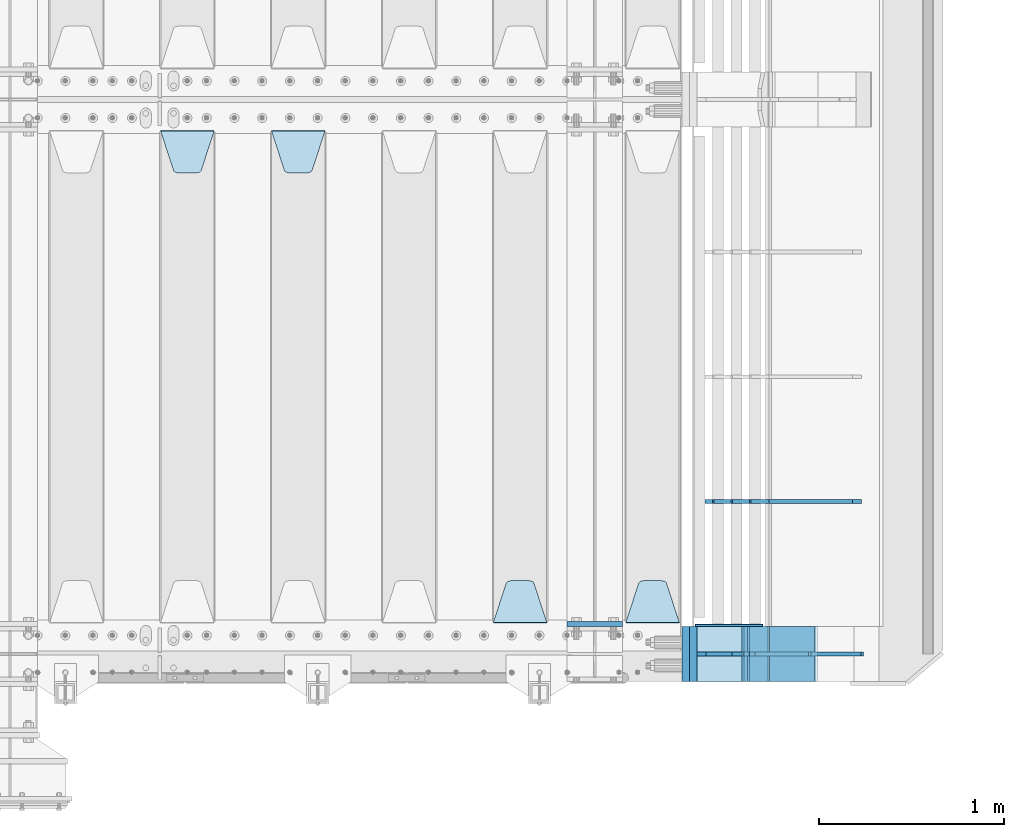
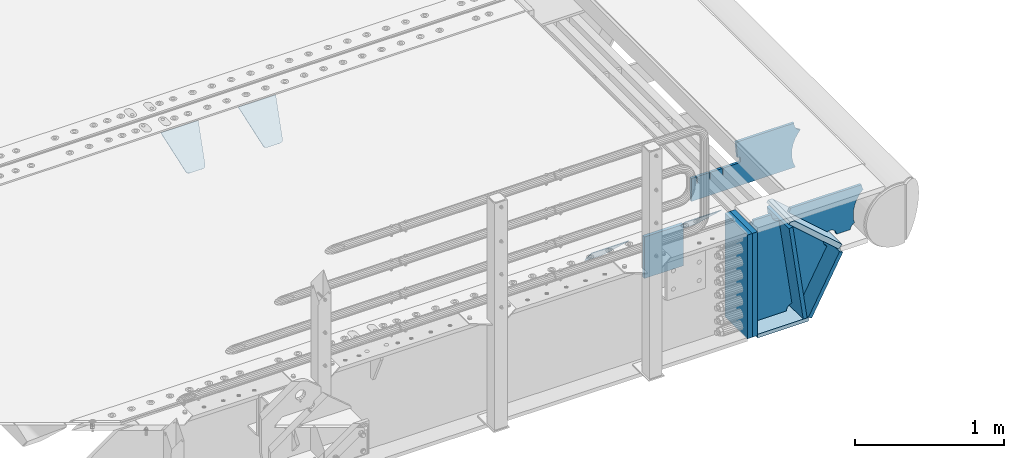
# One storey, part 185 of 219: 16 plates.
"""IFC2X3 building model written with IfcOpenShell, lengths in millimetres."""

from ifc_helpers import new_model, si_unit, frame, origin_with_axes, place, context, subcontext, project, spatial, faceted_brep, material, type_object, element, save


model = new_model("IFC2X3")

# Units and contexts
model_context = context("Model", 3, precision=1e-05, world=origin_with_axes())
body_context = subcontext(model_context, "Body", "Model", "MODEL_VIEW")
ifc_project = project(units=[si_unit("LENGTHUNIT", "METRE", prefix="MILLI"), si_unit("AREAUNIT", "SQUARE_METRE"), si_unit("VOLUMEUNIT", "CUBIC_METRE"), si_unit("MASSUNIT", "GRAM", prefix="KILO"), si_unit("TIMEUNIT", "SECOND"), si_unit("PLANEANGLEUNIT", "RADIAN"), si_unit("SOLIDANGLEUNIT", "STERADIAN"), si_unit("THERMODYNAMICTEMPERATUREUNIT", "DEGREE_CELSIUS"), si_unit("LUMINOUSINTENSITYUNIT", "LUMEN")], contexts=[model_context])

# Site, building, storey
site_placement = place(None, origin_with_axes())
site = spatial("IfcSite", under=ifc_project, at=site_placement, CompositionType="ELEMENT")
building_placement = place(site_placement, origin_with_axes())
building = spatial("IfcBuilding", under=site, at=building_placement, Name="Standard", CompositionType="ELEMENT")
storey_placement = place(building_placement, origin_with_axes())
storey = spatial("IfcBuildingStorey", under=building, at=storey_placement, Name="Undefined", CompositionType="ELEMENT", Elevation=0.0)

# Plates
ifc_material_1 = material(Name="STEEL/S355N")
plate_type_1 = type_object("IfcPlateType", PredefinedType="NOTDEFINED")
plate_1_placement = place(storey_placement, frame((13405.0, 24162.5, -340.000000000044), z_axis=(0.0, 0.0, 1.0), x_axis=(1.0, 0.0, 0.0)))
element("IfcPlate", 1, at=plate_1_placement, inside=storey, type_object=plate_type_1, material=ifc_material_1, context=body_context, shape_type="Brep", body=[
    faceted_brep([(0.0, -12.5, 0.0), (9.27684595808387e-10, -12.5, 340.0), (9.27684595808387e-10, 12.5, 340.0), (0.0, 12.5, 0.0), (300.0, -12.5, 340.0), (300.0, 12.5, 340.0), (300.0, -12.5, 0.0), (300.0, 12.5, 0.0)], [[[0, 1, 2, 3]], [[1, 4, 5, 2]], [[4, 6, 7, 5]], [[6, 0, 3, 7]], [[5, 7, 3, 2]], [[6, 4, 1, 0]]]),
])
plate_type_2 = type_object("IfcPlateType", PredefinedType="NOTDEFINED")
plate_2_placement = place(storey_placement, frame((14012.0, 24168.232233047, -1.76776695296758), z_axis=(0.0, 0.707106781186547, -0.707106781186548), x_axis=(-1.0, 0.0, 0.0)))
element("IfcPlate", 2, at=plate_2_placement, inside=storey, type_object=plate_type_2, material=ifc_material_1, context=body_context, shape_type="Brep", body=[
    faceted_brep([(0.0, -2.5, 0.0), (69.345504679477, -2.5, 300.171731424834), (69.345504679477, 2.49999999999636, 300.171731424831), (0.0, 2.5, 0.0), (70.9274061199576, -2.50000000000364, 304.8974424154), (70.9274061199576, 2.49999999999636, 304.8974424154), (73.3818627772307, -2.50000000000364, 309.234538108532), (73.3818627772307, 2.49999999999636, 309.234538108532), (76.6187032999569, -2.50000000000364, 313.023683126106), (76.6187032999569, 2.49999999999636, 313.023683126106), (80.5190132704993, -2.50000000000364, 316.125672595372), (80.5190132704993, 2.49999999999636, 316.125672595372), (84.9395038596831, -2.50000000000364, 318.426546230476), (84.9395038596831, 2.5, 318.426546230479), (89.7177759439237, -2.50000000000364, 319.841774983277), (89.7177759439237, 2.5, 319.841774983281), (94.6782862926502, -2.50000000000364, 320.319366455078), (94.6782862926502, 2.49999999999636, 320.319366455078), (195.32171370735, -2.50000000000364, 320.319366455078), (195.32171370735, 2.49999999999636, 320.319366455078), (200.282224056076, -2.50000000000364, 319.841774983277), (200.282224056076, 2.5, 319.841774983281), (205.060496140317, -2.50000000000364, 318.426546230476), (205.060496140317, 2.49999999999636, 318.426546230476), (209.480986729501, -2.50000000000364, 316.125672595372), (209.480986729501, 2.49999999999636, 316.125672595372), (213.381296700043, -2.50000000000364, 313.023683126106), (213.381296700043, 2.49999999999272, 313.023683126106), (216.618137222769, -2.50000000000364, 309.234538108529), (216.618137222769, 2.49999999999636, 309.234538108525), (219.072593880042, -2.50000000000364, 304.8974424154), (219.072593880042, 2.49999999999636, 304.8974424154), (220.654495320523, -2.5, 300.171731424834), (220.654495320523, 2.49999999999636, 300.171731424831), (290.0, -2.50000000000364, 3.63797880709171e-12), (290.0, 2.49999999999636, 0.0)], [[[0, 1, 2, 3]], [[1, 4, 5, 2]], [[4, 6, 7, 5]], [[6, 8, 9, 7]], [[8, 10, 11, 9]], [[10, 12, 13, 11]], [[12, 14, 15, 13]], [[14, 16, 17, 15]], [[16, 18, 19, 17]], [[18, 20, 21, 19]], [[20, 22, 23, 21]], [[22, 24, 25, 23]], [[24, 26, 27, 25]], [[26, 28, 29, 27]], [[28, 30, 31, 29]], [[30, 32, 33, 31]], [[32, 34, 35, 33]], [[34, 0, 3, 35]], [[5, 7, 9, 11, 13, 15, 17, 19, 21, 23, 25, 27, 29, 31, 33, 35, 3, 2]], [[34, 32, 30, 28, 26, 24, 22, 20, 18, 16, 14, 12, 10, 8, 6, 4, 1, 0]]]),
])
plate_3_placement = place(storey_placement, frame((13295.0, 24168.232233047, -1.76776695296758), z_axis=(0.0, 0.707106781186547, -0.707106781186548), x_axis=(-1.0, 0.0, 0.0)))
element("IfcPlate", 3, at=plate_3_placement, inside=storey, type_object=plate_type_2, material=ifc_material_1, context=body_context, shape_type="Brep", body=[
    faceted_brep([(0.0, -2.5, 0.0), (69.345504679477, -2.5, 300.171731424834), (69.345504679477, 2.49999999999636, 300.171731424831), (0.0, 2.5, 0.0), (70.9274061199576, -2.50000000000364, 304.8974424154), (70.9274061199576, 2.49999999999636, 304.8974424154), (73.3818627772307, -2.50000000000364, 309.234538108532), (73.3818627772307, 2.49999999999636, 309.234538108532), (76.6187032999569, -2.50000000000364, 313.023683126106), (76.6187032999569, 2.49999999999636, 313.023683126106), (80.5190132704993, -2.50000000000364, 316.125672595372), (80.5190132704993, 2.49999999999636, 316.125672595372), (84.9395038596831, -2.50000000000364, 318.426546230476), (84.9395038596831, 2.5, 318.426546230479), (89.7177759439237, -2.50000000000364, 319.841774983277), (89.7177759439237, 2.5, 319.841774983281), (94.6782862926502, -2.50000000000364, 320.319366455078), (94.6782862926502, 2.49999999999636, 320.319366455078), (195.32171370735, -2.50000000000364, 320.319366455078), (195.32171370735, 2.49999999999636, 320.319366455078), (200.282224056076, -2.50000000000364, 319.841774983277), (200.282224056076, 2.5, 319.841774983281), (205.060496140317, -2.50000000000364, 318.426546230476), (205.060496140317, 2.49999999999636, 318.426546230476), (209.480986729501, -2.50000000000364, 316.125672595372), (209.480986729501, 2.49999999999636, 316.125672595372), (213.381296700043, -2.50000000000364, 313.023683126106), (213.381296700043, 2.49999999999272, 313.023683126106), (216.618137222769, -2.50000000000364, 309.234538108529), (216.618137222769, 2.49999999999636, 309.234538108525), (219.072593880042, -2.50000000000364, 304.8974424154), (219.072593880042, 2.49999999999636, 304.8974424154), (220.654495320523, -2.5, 300.171731424834), (220.654495320523, 2.49999999999636, 300.171731424831), (290.0, -2.50000000000364, 3.63797880709171e-12), (290.0, 2.49999999999636, 0.0)], [[[0, 1, 2, 3]], [[1, 4, 5, 2]], [[4, 6, 7, 5]], [[6, 8, 9, 7]], [[8, 10, 11, 9]], [[10, 12, 13, 11]], [[12, 14, 15, 13]], [[14, 16, 17, 15]], [[16, 18, 19, 17]], [[18, 20, 21, 19]], [[20, 22, 23, 21]], [[22, 24, 25, 23]], [[24, 26, 27, 25]], [[26, 28, 29, 27]], [[28, 30, 31, 29]], [[30, 32, 33, 31]], [[32, 34, 35, 33]], [[34, 0, 3, 35]], [[5, 7, 9, 11, 13, 15, 17, 19, 21, 23, 25, 27, 29, 31, 33, 35, 3, 2]], [[34, 32, 30, 28, 26, 24, 22, 20, 18, 16, 14, 12, 10, 8, 6, 4, 1, 0]]]),
])
plate_4_placement = place(storey_placement, frame((11805.0, 26831.767766956, -1.76776695296758), z_axis=(0.0, -0.707106781186547, -0.707106781186548), x_axis=(1.0, 0.0, 0.0)))
element("IfcPlate", 4, at=plate_4_placement, inside=storey, type_object=plate_type_2, material=ifc_material_1, context=body_context, shape_type="Brep", body=[
    faceted_brep([(0.0, -2.5, 0.0), (69.345504679477, -2.5, 300.171731424834), (69.345504679477, 2.49999999999636, 300.171731424831), (0.0, 2.5, 0.0), (70.9274061199576, -2.50000000000364, 304.8974424154), (70.9274061199576, 2.49999999999636, 304.8974424154), (73.3818627772307, -2.50000000000364, 309.234538108532), (73.3818627772307, 2.49999999999636, 309.234538108532), (76.6187032999569, -2.50000000000364, 313.023683126106), (76.6187032999569, 2.49999999999636, 313.023683126106), (80.5190132704993, -2.50000000000364, 316.125672595372), (80.5190132704993, 2.49999999999636, 316.125672595372), (84.9395038596831, -2.50000000000364, 318.426546230476), (84.9395038596831, 2.5, 318.426546230479), (89.7177759439237, -2.50000000000364, 319.841774983277), (89.7177759439237, 2.5, 319.841774983281), (94.6782862926502, -2.50000000000364, 320.319366455078), (94.6782862926502, 2.49999999999636, 320.319366455078), (195.32171370735, -2.50000000000364, 320.319366455078), (195.32171370735, 2.49999999999636, 320.319366455078), (200.282224056076, -2.50000000000364, 319.841774983277), (200.282224056076, 2.5, 319.841774983281), (205.060496140317, -2.50000000000364, 318.426546230476), (205.060496140317, 2.49999999999636, 318.426546230476), (209.480986729501, -2.50000000000364, 316.125672595372), (209.480986729501, 2.49999999999636, 316.125672595372), (213.381296700043, -2.50000000000364, 313.023683126106), (213.381296700043, 2.49999999999272, 313.023683126106), (216.618137222769, -2.50000000000364, 309.234538108529), (216.618137222769, 2.49999999999636, 309.234538108525), (219.072593880042, -2.50000000000364, 304.8974424154), (219.072593880042, 2.49999999999636, 304.8974424154), (220.654495320523, -2.5, 300.171731424834), (220.654495320523, 2.49999999999636, 300.171731424831), (290.0, -2.50000000000364, 3.63797880709171e-12), (290.0, 2.49999999999636, 0.0)], [[[0, 1, 2, 3]], [[1, 4, 5, 2]], [[4, 6, 7, 5]], [[6, 8, 9, 7]], [[8, 10, 11, 9]], [[10, 12, 13, 11]], [[12, 14, 15, 13]], [[14, 16, 17, 15]], [[16, 18, 19, 17]], [[18, 20, 21, 19]], [[20, 22, 23, 21]], [[22, 24, 25, 23]], [[24, 26, 27, 25]], [[26, 28, 29, 27]], [[28, 30, 31, 29]], [[30, 32, 33, 31]], [[32, 34, 35, 33]], [[34, 0, 3, 35]], [[5, 7, 9, 11, 13, 15, 17, 19, 21, 23, 25, 27, 29, 31, 33, 35, 3, 2]], [[34, 32, 30, 28, 26, 24, 22, 20, 18, 16, 14, 12, 10, 8, 6, 4, 1, 0]]]),
])
plate_5_placement = place(storey_placement, frame((11205.0, 26831.767766956, -1.76776695296758), z_axis=(0.0, -0.707106781186547, -0.707106781186548), x_axis=(1.0, 0.0, 0.0)))
element("IfcPlate", 5, at=plate_5_placement, inside=storey, type_object=plate_type_2, material=ifc_material_1, context=body_context, shape_type="Brep", body=[
    faceted_brep([(0.0, -2.5, 0.0), (69.345504679477, -2.5, 300.171731424834), (69.345504679477, 2.49999999999636, 300.171731424831), (0.0, 2.5, 0.0), (70.9274061199576, -2.50000000000364, 304.8974424154), (70.9274061199576, 2.49999999999636, 304.8974424154), (73.3818627772307, -2.50000000000364, 309.234538108532), (73.3818627772307, 2.49999999999636, 309.234538108532), (76.6187032999569, -2.50000000000364, 313.023683126106), (76.6187032999569, 2.49999999999636, 313.023683126106), (80.5190132704993, -2.50000000000364, 316.125672595372), (80.5190132704993, 2.49999999999636, 316.125672595372), (84.9395038596831, -2.50000000000364, 318.426546230476), (84.9395038596831, 2.5, 318.426546230479), (89.7177759439237, -2.50000000000364, 319.841774983277), (89.7177759439237, 2.5, 319.841774983281), (94.6782862926502, -2.50000000000364, 320.319366455078), (94.6782862926502, 2.49999999999636, 320.319366455078), (195.32171370735, -2.50000000000364, 320.319366455078), (195.32171370735, 2.49999999999636, 320.319366455078), (200.282224056076, -2.50000000000364, 319.841774983277), (200.282224056076, 2.5, 319.841774983281), (205.060496140317, -2.50000000000364, 318.426546230476), (205.060496140317, 2.49999999999636, 318.426546230476), (209.480986729501, -2.50000000000364, 316.125672595372), (209.480986729501, 2.49999999999636, 316.125672595372), (213.381296700043, -2.50000000000364, 313.023683126106), (213.381296700043, 2.49999999999272, 313.023683126106), (216.618137222769, -2.50000000000364, 309.234538108529), (216.618137222769, 2.49999999999636, 309.234538108525), (219.072593880042, -2.50000000000364, 304.8974424154), (219.072593880042, 2.49999999999636, 304.8974424154), (220.654495320523, -2.5, 300.171731424834), (220.654495320523, 2.49999999999636, 300.171731424831), (290.0, -2.50000000000364, 3.63797880709171e-12), (290.0, 2.49999999999636, 0.0)], [[[0, 1, 2, 3]], [[1, 4, 5, 2]], [[4, 6, 7, 5]], [[6, 8, 9, 7]], [[8, 10, 11, 9]], [[10, 12, 13, 11]], [[12, 14, 15, 13]], [[14, 16, 17, 15]], [[16, 18, 19, 17]], [[18, 20, 21, 19]], [[20, 22, 23, 21]], [[22, 24, 25, 23]], [[24, 26, 27, 25]], [[26, 28, 29, 27]], [[28, 30, 31, 29]], [[30, 32, 33, 31]], [[32, 34, 35, 33]], [[34, 0, 3, 35]], [[5, 7, 9, 11, 13, 15, 17, 19, 21, 23, 25, 27, 29, 31, 33, 35, 3, 2]], [[34, 32, 30, 28, 26, 24, 22, 20, 18, 16, 14, 12, 10, 8, 6, 4, 1, 0]]]),
])
plate_type_3 = type_object("IfcPlateType", PredefinedType="NOTDEFINED")
plate_6_placement = place(storey_placement, frame((14748.9988298898, 24149.9999999992, -367.999999998825), z_axis=(-0.752989422949574, 0.0, 0.658032619955932), x_axis=(0.0, -1.0, 0.0)))
element("IfcPlate", 6, at=plate_6_placement, inside=storey, type_object=plate_type_3, material=ifc_material_1, context=body_context, shape_type="Brep", body=[
    faceted_brep([(-8.11269273981452e-10, 20.0, 490.76626560162), (0.0, -0.303811250943909, 513.999999999998), (300.0, -0.303811250943909, 513.999999999998), (300.0, 20.0, 490.76626560162), (300.0, -20.0, -1.81898940354586e-12), (300.0, -20.0, 514.0), (0.0, -20.0, 514.0), (0.0, -20.0, 0.0), (0.0, 20.0, 0.0), (300.0, 20.0, -1.81898940354586e-12)], [[[0, 1, 2, 3]], [[4, 5, 6, 7]], [[4, 7, 8, 9]], [[9, 8, 0, 3]], [[5, 4, 9, 3, 2]], [[6, 5, 2, 1]], [[8, 7, 6, 1, 0]]]),
])
ifc_material_2 = material()
for number, where, z_axis, x_axis in (
    (7, (14086.9988298907, 24150.0, -869.999999999526), (0.0, 0.0, 1.0), (0.0, -1.0, 0.0)),
    (8, (14047.0, 24150.0, -870.0), (0.0, 0.0, 1.0), (0.0, -1.0, 0.0)),
):
    element("IfcPlate", number, at=place(storey_placement, frame(where, z_axis=z_axis, x_axis=x_axis)), inside=storey, type_object=plate_type_3, material=ifc_material_2, context=body_context, shape_type="Brep", body=[
        faceted_brep([(0.0, -20.0, 0.0), (0.0, -20.0, 850.0), (0.0, 20.0, 850.0), (0.0, 20.0, 0.0), (300.0, -20.0, 850.0), (300.0, 20.0, 850.0), (300.0, -20.0, -1.81898940354586e-12), (300.0, 20.0, -1.81898940354586e-12)], [[[0, 1, 2, 3]], [[1, 4, 5, 2]], [[4, 6, 7, 5]], [[6, 0, 3, 7]], [[5, 7, 3, 2]], [[6, 4, 1, 0]]]),
    ])
plate_type_4 = type_object("IfcPlateType", PredefinedType="NOTDEFINED")
plate_7_placement = place(storey_placement, frame((14345.9988298891, 24000.0, -30.0000000027761), z_axis=(0.0, 0.0, -1.0), x_axis=(-1.0, 0.0, 0.0)))
element("IfcPlate", 9, at=plate_7_placement, inside=storey, type_object=plate_type_4, material=ifc_material_1, context=body_context, shape_type="Brep", body=[
    faceted_brep([(-9.00602409638486, -10.0, 65.0), (-108.137843376921, -10.0, 780.473130459514), (-108.137843376921, 10.0, 780.473130459514), (-9.00602409638486, 10.0, 65.0), (-94.4157884488395, -10.0, 784.433672138112), (-94.4157884488395, 10.0, 784.433672138112), (-82.3732461236723, -10.0, 792.112074067144), (-82.3732461236723, 10.0, 792.112074067144), (-72.9927947992364, -10.0, 802.881837982249), (-72.9927947992364, 10.0, 802.881837982249), (-67.0398068183713, -10.0, 815.864234368775), (-67.0398068183713, 10.0, 815.864234368775), (-65.0, -10.0, 830.0), (-65.0, 10.0, 830.0), (189.0, -10.0, 830.0), (189.0, 10.0, 830.0), (191.447174185243, -10.0, 814.549150281253), (191.447174185243, 10.0, 814.549150281253), (198.549150281253, -10.0, 800.610737385376), (198.549150281253, 10.0, 800.610737385376), (209.610737385376, -10.0, 789.549150281253), (209.610737385376, 10.0, 789.549150281253), (223.549150281253, -10.0, 782.447174185242), (223.549150281253, 10.0, 782.447174185242), (239.0, -10.0, 780.0), (239.0, 10.0, 780.0), (239.0, -10.0, 50.0), (239.0, 10.0, 50.0), (223.549150281253, -10.0, 47.5528258147577), (223.549150281253, 10.0, 47.5528258147577), (209.610737385376, -10.0, 40.4508497187474), (209.610737385376, 10.0, 40.4508497187474), (198.549150281253, -10.0, 29.3892626146237), (198.549150281253, 10.0, 29.3892626146237), (191.447174185243, -10.0, 15.4508497187474), (191.447174185243, 10.0, 15.4508497187474), (189.0, -10.0, 0.0), (189.0, 10.0, 0.0), (50.4776502774184, -10.0, 0.0), (50.4776502774184, 10.0, 0.0), (47.3830020671794, -10.0, 22.3352870825933), (47.3830020671794, 10.0, 22.3352870825933), (42.8384615202795, -10.0, 37.3040735979326), (42.8384615202795, 10.0, 37.3040735979326), (33.8907372011709, -10.0, 50.1358952937587), (33.8907372011709, 10.0, 50.1358952937587), (21.4156947086703, -10.0, 59.5746840579253), (21.4156947086703, 10.0, 59.5746840579253), (6.63447812067716, -10.0, 64.6965054822873), (6.63447812067716, 10.0, 64.6965054822873)], [[[0, 1, 2, 3]], [[1, 4, 5, 2]], [[4, 6, 7, 5]], [[6, 8, 9, 7]], [[8, 10, 11, 9]], [[10, 12, 13, 11]], [[12, 14, 15, 13]], [[14, 16, 17, 15]], [[16, 18, 19, 17]], [[18, 20, 21, 19]], [[20, 22, 23, 21]], [[22, 24, 25, 23]], [[24, 26, 27, 25]], [[26, 28, 29, 27]], [[28, 30, 31, 29]], [[30, 32, 33, 31]], [[32, 34, 35, 33]], [[34, 36, 37, 35]], [[36, 38, 39, 37]], [[38, 40, 41, 39]], [[40, 42, 43, 41]], [[42, 44, 45, 43]], [[44, 46, 47, 45]], [[46, 48, 49, 47]], [[48, 0, 3, 49]], [[5, 7, 9, 11, 13, 15, 17, 19, 21, 23, 25, 27, 29, 31, 33, 35, 37, 39, 41, 43, 45, 47, 49, 3, 2]], [[48, 46, 44, 42, 40, 38, 36, 34, 32, 30, 28, 26, 24, 22, 20, 18, 16, 14, 12, 10, 8, 6, 4, 1, 0]]]),
])
plate_type_5 = type_object("IfcPlateType", PredefinedType="NOTDEFINED")
plate_8_placement = place(storey_placement, frame((15063.9988298898, 23999.9999999994, -29.9999999988253), z_axis=(-0.000446694000103943, 0.0, -0.99999990023223), x_axis=(-0.99999990023223, 0.0, 0.000446694000103737)))
element("IfcPlate", 10, at=plate_8_placement, inside=storey, type_object=plate_type_5, material=ifc_material_1, context=body_context, shape_type="Brep", body=[
    faceted_brep([(125.007775472981, 10.0, 291.842314882029), (131.755016800049, 10.0, 263.793234614468), (131.755016800049, -10.0, 263.793234614468), (125.007775472981, -10.0, 291.842314882029), (134.899927074479, 10.0, 224.060281342732), (134.899927074479, -10.0, 224.060281342732), (131.790514995217, 10.0, 184.324534302446), (131.790514995217, -10.0, 184.324534302446), (122.503344607203, 10.0, 145.564419461128), (122.503344607203, -10.0, 145.564419461128), (107.267096867743, 10.0, 108.734339483616), (107.267096867743, -10.0, 108.734339483616), (86.4569387623869, 10.0, 74.741173170983), (86.4569387623869, -10.0, 74.741173170983), (60.5852854486457, 10.0, 44.4219450946983), (60.5852854486457, -10.0, 44.4219450946983), (56.2519855253049, 10.0, 40.7176084148888), (56.2519855253049, -10.0, 40.7176084148888), (136.409234539124, -10.0, 297.721677540594), (147.38699118058, -10.0, 308.778803581017), (147.38699118058, 10.0, 308.778803581017), (136.409234539124, 10.0, 297.721677540594), (154.428166132753, -10.0, 322.678193223937), (154.428166132753, 10.0, 322.678193223937), (156.849001662975, -10.0, 338.070097995228), (156.849001662975, 10.0, 338.070097995228), (264.849004013293, -10.0, 338.118348049693), (264.849004013293, 10.0, 338.118348049693), (267.628767119546, -10.0, 321.701412969031), (267.628767119546, 10.0, 321.701412969031), (275.645118712177, -10.0, 307.107546191754), (275.645118712177, 10.0, 307.107546191754), (288.009068357207, -10.0, 295.955165748785), (288.009068357207, 10.0, 295.955165748785), (303.34948944753, -10.0, 289.481038692482), (303.34948944753, 10.0, 289.481038692482), (319.965173216926, -10.0, 288.403127172445), (319.965173216926, 10.0, 288.403127172445), (336.013487920229, -10.0, 292.840968489265), (336.013487920229, 10.0, 292.840968489265), (335.869079589842, -10.0, 293.150054931641), (335.869079589842, 10.0, 293.150054931641), (633.937057436442, -10.0, 32.8861672876965), (633.937057436442, 10.0, 32.8861672876965), (628.672097726396, -10.0, 25.6357574923157), (628.672097726396, 10.0, 25.6357574923157), (624.785781531269, -10.0, 17.5620477266101), (624.785781531269, 10.0, 17.5620477266101), (622.402919050599, -10.0, 8.92432757904926), (622.402919050599, 10.0, 8.92432757904926), (621.600036621092, -10.0, -8.74681660434362e-10), (621.600036621092, 10.0, -8.74681660434362e-10), (69.9999999999982, -10.0, -9.85025394584227e-11), (69.9999999999982, 10.0, -9.85025394584227e-11), (67.7728137216582, -10.0, 17.5170123094482), (67.7728137216582, 10.0, 17.5170123094482), (61.2329794213983, -10.0, 33.9193489203215), (61.2329794213983, 10.0, 33.9193489203215)], [[[0, 1, 2, 3]], [[4, 5, 2, 1]], [[6, 7, 5, 4]], [[8, 9, 7, 6]], [[10, 11, 9, 8]], [[12, 13, 11, 10]], [[14, 15, 13, 12]], [[16, 17, 15, 14]], [[18, 19, 20, 21]], [[19, 22, 23, 20]], [[22, 24, 25, 23]], [[24, 26, 27, 25]], [[26, 28, 29, 27]], [[28, 30, 31, 29]], [[30, 32, 33, 31]], [[32, 34, 35, 33]], [[34, 36, 37, 35]], [[36, 38, 39, 37]], [[38, 40, 41, 39]], [[40, 42, 43, 41]], [[42, 44, 45, 43]], [[44, 46, 47, 45]], [[46, 48, 49, 47]], [[48, 50, 51, 49]], [[50, 52, 53, 51]], [[52, 54, 55, 53]], [[54, 56, 57, 55]], [[12, 10, 8, 6, 4, 1, 0, 21, 20, 23, 25, 27, 29, 31, 33, 35, 37, 39, 41, 43, 45, 47, 49, 51, 53, 55, 57, 16, 14]], [[18, 21, 0, 3]], [[56, 54, 52, 50, 48, 46, 44, 42, 40, 38, 36, 34, 32, 30, 28, 26, 24, 22, 19, 18, 3, 2, 5, 7, 9, 11, 13, 15, 17]], [[57, 56, 17, 16]]]),
])
plate_type_6 = type_object("IfcPlateType", PredefinedType="NOTDEFINED")
plate_9_placement = place(storey_placement, frame((14748.0025685034, 24000.000000001, -393.99668820393), z_axis=(-0.658066357015091, 0.0, -0.752959939017267), x_axis=(-0.752959939017267, 0.0, 0.658066357015092)))
element("IfcPlate", 11, at=plate_9_placement, inside=storey, type_object=plate_type_6, material=ifc_material_1, context=body_context, shape_type="Brep", body=[
    faceted_brep([(-11.3595226159596, -10.0, 48.6925173505897), (-112.015767301033, -10.0, 480.154833723627), (-112.015767301033, 10.0, 480.154833723627), (-11.3595226159596, 10.0, 48.6925173505897), (-104.567323293641, -10.0, 482.519601382539), (-104.567323293641, 10.0, 482.519601382539), (-97.5783311599989, -10.0, 486.016090073754), (-97.5783311599989, 10.0, 486.016090073754), (-91.2195220373815, -10.0, 490.558885551654), (-91.2195220373815, 10.0, 490.558885551654), (-85.646232588424, -10.0, 496.037013784004), (-85.646232588424, 10.0, 496.037013784004), (447.024482710496, -10.0, 32.8103372896367), (447.024482710496, 10.0, 32.8103372896367), (441.786973010394, -10.0, 25.5709623937273), (441.786973010394, 10.0, 25.5709623937273), (437.921644570128, -10.0, 17.5149526624118), (437.921644570128, 10.0, 17.5149526624118), (435.551940606496, -10.0, 8.89958500531611), (435.551940606496, 10.0, 8.89958500531611), (434.753540039064, -10.0, -5.18411980010569e-10), (434.753540039064, 10.0, -5.18411980010569e-10), (50.0, -10.0, 0.0), (50.0, 10.0, 0.0), (47.7668538974249, -10.0, 14.7759151575156), (47.7668538974249, 10.0, 14.7759151575156), (41.2668932502802, -10.0, 28.2319592212425), (41.2668932502802, 10.0, 28.2319592212425), (31.0807325300175, -10.0, 39.1661596968279), (31.0807325300175, 10.0, 39.1661596968279), (18.1182591411489, -10.0, 46.6018098971927), (18.1182591411489, 10.0, 46.6018098971927), (3.53735696080548, -10.0, 49.8747140917294), (3.53735696080548, 10.0, 49.8747140917294)], [[[0, 1, 2, 3]], [[1, 4, 5, 2]], [[4, 6, 7, 5]], [[6, 8, 9, 7]], [[8, 10, 11, 9]], [[10, 12, 13, 11]], [[12, 14, 15, 13]], [[14, 16, 17, 15]], [[16, 18, 19, 17]], [[18, 20, 21, 19]], [[20, 22, 23, 21]], [[22, 24, 25, 23]], [[24, 26, 27, 25]], [[26, 28, 29, 27]], [[28, 30, 31, 29]], [[30, 32, 33, 31]], [[32, 0, 3, 33]], [[5, 7, 9, 11, 13, 15, 17, 19, 21, 23, 25, 27, 29, 31, 33, 3, 2]], [[32, 30, 28, 26, 24, 22, 20, 18, 16, 14, 12, 10, 8, 6, 4, 1, 0]]]),
])
plate_type_7 = type_object("IfcPlateType", PredefinedType="NOTDEFINED")
plate_10_placement = place(storey_placement, frame((14499.9988298891, 24150.0, -875.000000002776), z_axis=(0.0, -1.0, 0.0), x_axis=(-1.0, 0.0, 0.0)))
element("IfcPlate", 12, at=plate_10_placement, inside=storey, type_object=plate_type_7, material=ifc_material_1, context=body_context, shape_type="Brep", body=[
    faceted_brep([(0.0, -15.0, 0.0), (0.0, -15.0, 300.0), (0.0, 15.0, 300.0), (0.0, 15.0, 0.0), (393.0, -15.0, 300.0), (393.0, 15.0, 300.0), (393.0, -15.0, 0.0), (393.0, 15.0, 0.0)], [[[0, 1, 2, 3]], [[1, 4, 5, 2]], [[4, 6, 7, 5]], [[6, 0, 3, 7]], [[5, 7, 3, 2]], [[6, 4, 1, 0]]]),
])
plate_11_placement = place(storey_placement, frame((14476.1480677227, 24150.000000001, -862.083788726895), z_axis=(-0.13917301105301, 0.0, 0.990268081377179), x_axis=(0.0, -1.0, 0.0)))
element("IfcPlate", 13, at=plate_11_placement, inside=storey, type_object=plate_type_7, material=ifc_material_1, context=body_context, shape_type="Brep", body=[
    faceted_brep([(1.00408215075731e-09, 14.9994702460517, -0.00376939769603268), (300.0, 15.0, 0.0), (300.0, -14.9999999999982, 4.21237841384573), (0.0, -14.9999999999982, 4.21237841384573), (0.0, -15.0, 792.0), (300.0, -15.0, 792.0), (300.0, 15.0, 792.0), (0.0, 15.0, 792.0)], [[[0, 1, 2, 3]], [[4, 5, 6, 7]], [[4, 7, 0, 3]], [[5, 4, 3, 2]], [[6, 5, 2, 1]], [[7, 6, 1, 0]]]),
])
plate_12_placement = place(storey_placement, frame((14513.2468009574, 24150.000000001, -867.038754737571), z_axis=(0.469471552246178, 0.0, 0.882947598462992), x_axis=(0.0, -1.0, 0.0)))
element("IfcPlate", 14, at=plate_12_placement, inside=storey, type_object=plate_type_7, material=ifc_material_1, context=body_context, shape_type="Brep", body=[
    faceted_brep([(0.0, -15.0, 0.0), (0.0, -14.9999999999982, 515.000000000001), (0.0, 15.0000000000018, 515.000000000001), (0.0, 15.0, 0.0), (300.0, -14.9999999999982, 515.000000000001), (300.0, 15.0000000000018, 515.000000000001), (300.0, -15.0, 0.0), (300.0, 15.0, 0.0)], [[[0, 1, 2, 3]], [[1, 4, 5, 2]], [[4, 6, 7, 5]], [[6, 0, 3, 7]], [[5, 7, 3, 2]], [[6, 4, 1, 0]]]),
])
plate_type_8 = type_object("IfcPlateType", PredefinedType="NOTDEFINED")
plate_13_placement = place(storey_placement, frame((14992.9182339676, 24824.9992828369, -374.002067436517), z_axis=(0.0, 0.0, 1.0), x_axis=(-1.0, 0.0, 0.0)))
element("IfcPlate", 15, at=plate_13_placement, inside=storey, type_object=plate_type_8, material=ifc_material_1, context=body_context, shape_type="Brep", body=[
    faceted_brep([(801.919404066546, -10.0, 188.0), (801.919404066546, 10.0, 188.0), (801.919404066546, 10.0, 132.002067436952), (801.919404066546, -9.99999999999636, 132.002067436952), (793.919404066546, 10.0, 132.002067436952), (793.919404066546, -9.99999999999636, 132.002067436952), (793.919404066546, 10.0, 180.002067436952), (793.919404066546, -10.0, 180.002067436952), (793.527856196908, 10.0, 182.474203391951), (793.527856196908, -10.0, 182.474203391951), (792.391540021546, 10.0, 184.704349455291), (792.391540021546, -10.0, 184.704349455291), (790.621686084885, 10.0, 186.474203391951), (790.621686084885, -10.0, 186.474203391951), (788.391540021546, 10.0, 187.610519567313), (788.391540021546, -10.0, 187.610519567313), (785.919404066546, -10.0, 188.002067436952), (785.919404066546, 10.0, 188.0), (841.0, -10.0, 188.0), (841.0, -10.0, 0.0), (841.0, 10.0, 0.0), (841.0, 10.0, 188.0), (33.3619566736033, -10.0, 0.0), (33.3619566736033, 10.0, 0.0), (36.2350612208174, -10.0, 4.68848050267013), (36.2350612208174, 10.0, 4.68848050267013), (51.487759215941, -10.0, 41.5117508652784), (51.487759215941, 10.0, 41.5117508652784), (60.792242588137, -10.0, 80.2677133162964), (60.792242588137, 10.0, 80.2677133162964), (63.9194040769726, -10.0, 120.002067436515), (63.9194040769726, 10.0, 120.002067436515), (60.792242588137, -10.0, 159.736421556734), (60.792242588137, 10.0, 159.736421556734), (51.487759215941, -10.0, 198.492384007752), (51.487759215941, 10.0, 198.492384007752), (36.2350612208174, -10.0, 235.31565437036), (36.2350612208174, 10.0, 235.31565437036), (15.4097206482093, -10.0, 269.299521518803), (15.4097206482093, 10.0, 269.299521518803), (-3.35474438098936, -10.0, 291.269887256574), (-3.35474438098936, 10.0, 291.269887256574), (-2.36881039375294, -10.0, 291.426043859339), (-2.36881039375294, 10.0, 291.426043859339), (17.1449676604734, -10.0, 301.368810393754), (17.1449676604734, 10.0, 301.368810393754), (32.6311896062471, -10.0, 316.855032339527), (32.6311896062471, 10.0, 316.855032339527), (42.5739561406608, -10.0, 336.368810393754), (42.5739561406608, 10.0, 336.368810393754), (46.0, -10.0, 358.0), (46.0, 10.0, 358.0), (45.0495205499192, -10.0, 364.001091067617), (45.0495205499192, 10.0, 364.001091067617), (495.040008544922, -10.0, 364.010009765625), (495.040008544922, 10.0, 364.010009765625), (483.600036621094, -10.0, 233.759994506836), (483.600036621094, 10.0, 233.759994506836), (472.0, -10.0, 233.759994506836), (472.0, 10.0, 233.759994506836), (468.909830056251, -10.0, 233.270559669787), (468.909830056251, 10.0, 233.270559669787), (466.122147477075, -10.0, 231.850164450585), (466.122147477075, 10.0, 231.850164450585), (463.909830056251, -10.0, 229.637847029761), (463.909830056251, 10.0, 229.637847029761), (462.489434837049, -10.0, 226.850164450585), (462.489434837049, 10.0, 226.850164450585), (462.0, -10.0, 223.759994506836), (462.0, 10.0, 223.759994506836), (462.0, -10.0, 198.0), (462.0, 10.0, 198.0), (462.489434837049, -10.0, 194.909830056251), (462.489434837049, 10.0, 194.909830056251), (463.909830056251, -10.0, 192.122147477075), (463.909830056251, 10.0, 192.122147477075), (466.122147477075, -10.0, 189.909830056251), (466.122147477075, 10.0, 189.909830056251), (468.909830056251, -10.0, 188.489434837048), (468.909830056251, 10.0, 188.489434837048), (472.0, -10.0, 188.0), (472.0, 10.0, 188.0), (585.919404066546, -10.0, 188.002067436952), (585.919404066546, 10.0, 188.0), (588.391540021546, -10.0, 187.610519567313), (588.391540021546, 10.0, 187.610519567313), (590.621686084885, -10.0, 186.474203391951), (590.621686084885, 10.0, 186.474203391951), (592.391540021546, -10.0, 184.704349455291), (592.391540021546, 10.0, 184.704349455291), (593.527856196908, -10.0, 182.474203391951), (593.527856196908, 10.0, 182.474203391951), (593.919404066546, -10.0, 180.002067436952), (593.919404066546, 10.0, 180.002067436952), (593.919404066546, -10.0, 132.002067436952), (593.919404066546, 10.0, 132.002067436952), (601.919404066546, -10.0, 132.002067436952), (601.919404066546, 10.0, 132.002067436952), (601.919404066546, -10.0, 188.0), (601.919404066546, 10.0, 188.0), (685.919404066546, -10.0, 188.002067436952), (685.919404066546, 10.0, 188.0), (688.391540021546, -10.0, 187.610519567313), (688.391540021546, 10.0, 187.610519567313), (690.621686084885, -10.0, 186.474203391951), (690.621686084885, 10.0, 186.474203391951), (692.391540021546, -10.0, 184.704349455291), (692.391540021546, 10.0, 184.704349455291), (693.527856196908, -10.0, 182.474203391951), (693.527856196908, 10.0, 182.474203391951), (693.919404066546, -10.0, 180.002067436952), (693.919404066546, 10.0, 180.002067436952), (693.919404066546, -10.0, 132.002067436952), (693.919404066546, 10.0, 132.002067436952), (701.919404066546, -10.0, 132.002067436952), (701.919404066546, 10.0, 132.002067436952), (701.919404066546, -10.0, 188.0), (701.919404066546, 10.0, 188.0)], [[[0, 1, 2, 3]], [[3, 2, 4, 5]], [[5, 4, 6, 7]], [[7, 6, 8, 9]], [[9, 8, 10, 11]], [[11, 10, 12, 13]], [[13, 12, 14, 15]], [[16, 15, 14, 17]], [[18, 19, 20, 21]], [[20, 19, 22, 23]], [[22, 24, 25, 23]], [[26, 27, 25, 24]], [[28, 29, 27, 26]], [[30, 31, 29, 28]], [[32, 33, 31, 30]], [[34, 35, 33, 32]], [[36, 37, 35, 34]], [[38, 39, 37, 36]], [[39, 38, 40, 41]], [[40, 42, 43, 41]], [[44, 45, 43, 42]], [[46, 47, 45, 44]], [[48, 49, 47, 46]], [[50, 51, 49, 48]], [[52, 53, 51, 50]], [[54, 55, 53, 52]], [[54, 56, 57, 55]], [[56, 58, 59, 57]], [[58, 60, 61, 59]], [[60, 62, 63, 61]], [[62, 64, 65, 63]], [[64, 66, 67, 65]], [[66, 68, 69, 67]], [[68, 70, 71, 69]], [[70, 72, 73, 71]], [[72, 74, 75, 73]], [[74, 76, 77, 75]], [[76, 78, 79, 77]], [[78, 80, 81, 79]], [[81, 80, 82, 83]], [[82, 84, 85, 83]], [[86, 87, 85, 84]], [[88, 89, 87, 86]], [[90, 91, 89, 88]], [[92, 93, 91, 90]], [[94, 95, 93, 92]], [[96, 97, 95, 94]], [[98, 99, 97, 96]], [[99, 98, 100, 101]], [[100, 102, 103, 101]], [[104, 105, 103, 102]], [[106, 107, 105, 104]], [[108, 109, 107, 106]], [[110, 111, 109, 108]], [[112, 113, 111, 110]], [[114, 115, 113, 112]], [[116, 117, 115, 114]], [[117, 116, 16, 17]], [[12, 10, 8, 6, 4, 2, 1, 21, 20, 23, 25, 27, 29, 31, 33, 35, 37, 39, 41, 43, 45, 47, 49, 51, 53, 55, 57, 59, 61, 63, 65, 67, 69, 71, 73, 75, 77, 79, 81, 83, 85, 87, 89, 91, 93, 95, 97, 99, 101, 103, 105, 107, 109, 111, 113, 115, 117, 17, 14]], [[18, 21, 1, 0]], [[116, 114, 112, 110, 108, 106, 104, 102, 100, 98, 96, 94, 92, 90, 88, 86, 84, 82, 80, 78, 76, 74, 72, 70, 68, 66, 64, 62, 60, 58, 56, 54, 52, 50, 48, 46, 44, 42, 40, 38, 36, 34, 32, 30, 28, 26, 24, 22, 19, 18, 0, 3, 5, 7, 9, 11, 13, 15, 16]]]),
])
plate_type_9 = type_object("IfcPlateType", PredefinedType="NOTDEFINED")
plate_14_placement = place(storey_placement, frame((14461.998829901, 24155.0, -249.999999999564), z_axis=(-1.0, 0.0, 0.0), x_axis=(0.0, 0.0, 1.0)))
element("IfcPlate", 16, at=plate_14_placement, inside=storey, type_object=plate_type_9, material=ifc_material_1, context=body_context, shape_type="Brep", body=[
    faceted_brep([(0.0, -5.0, 0.0), (0.0, -5.0, 365.0), (0.0, 5.0, 365.0), (0.0, 5.0, 0.0), (80.0, -5.0, 365.0), (80.0, 5.0, 365.0), (80.0, -5.0, 0.0), (80.0, 5.0, 0.0)], [[[0, 1, 2, 3]], [[1, 4, 5, 2]], [[4, 6, 7, 5]], [[6, 0, 3, 7]], [[5, 7, 3, 2]], [[6, 4, 1, 0]]]),
])

save(model, "model.ifc")
